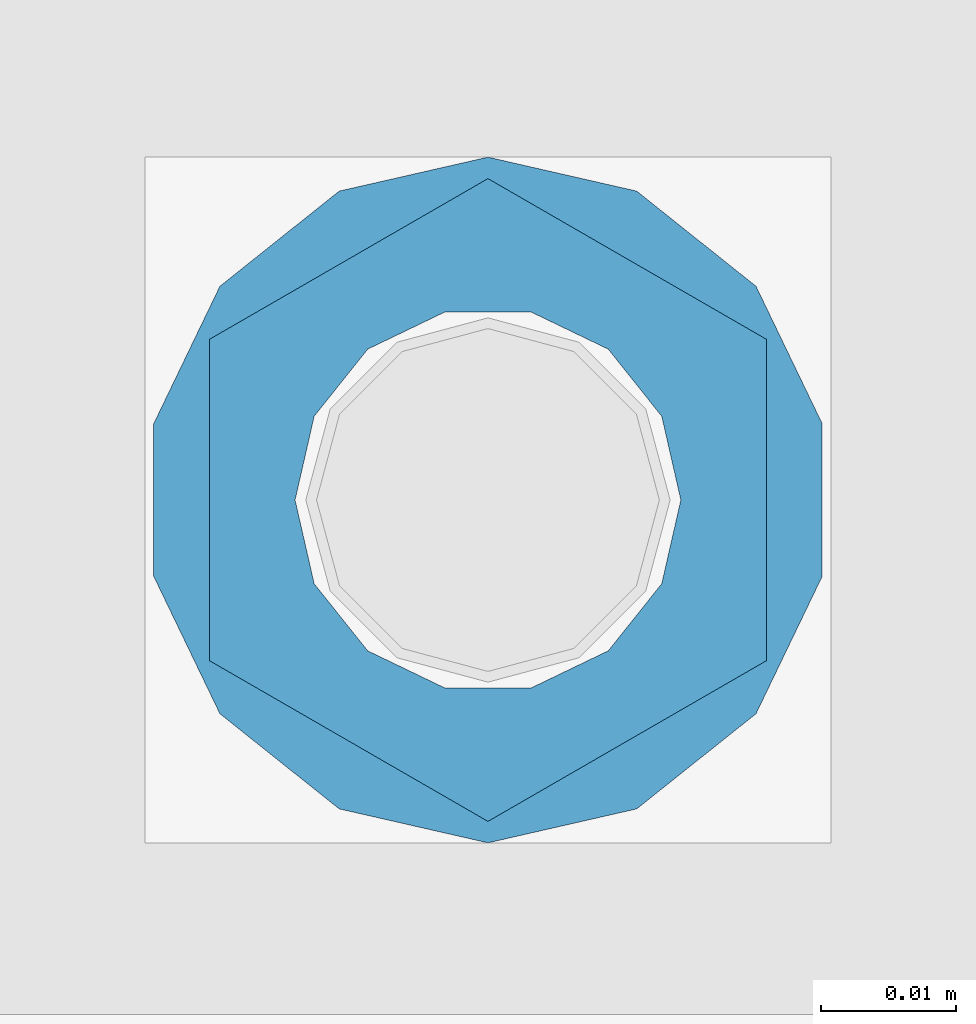
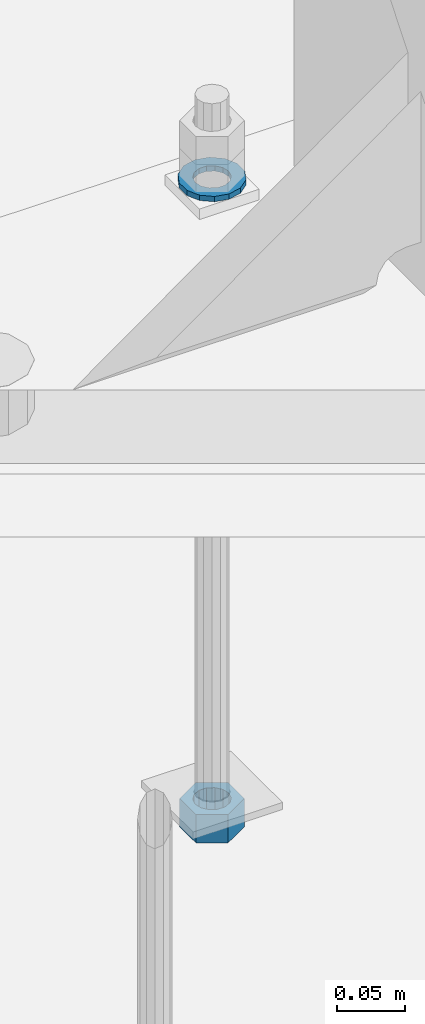
# One storey, part 1027 of 1763: 2 columns, 1 element without a shape of its own.
"""IFC2X3 building model written with IfcOpenShell, lengths in millimetres."""

from ifc_helpers import new_model, si_unit, frame, origin_with_axes, place, context, subcontext, project, spatial, faceted_brep, material, type_object, element, aggregate, save


model = new_model("IFC2X3")

# Units and contexts
model_context = context("Model", 3, precision=1e-05, world=origin_with_axes())
body_context = subcontext(model_context, "Body", "Model", "MODEL_VIEW")
ifc_project = project(units=[si_unit("LENGTHUNIT", "METRE", prefix="MILLI"), si_unit("AREAUNIT", "SQUARE_METRE"), si_unit("VOLUMEUNIT", "CUBIC_METRE"), si_unit("MASSUNIT", "GRAM", prefix="KILO"), si_unit("TIMEUNIT", "SECOND"), si_unit("PLANEANGLEUNIT", "RADIAN"), si_unit("SOLIDANGLEUNIT", "STERADIAN"), si_unit("THERMODYNAMICTEMPERATUREUNIT", "DEGREE_CELSIUS"), si_unit("LUMINOUSINTENSITYUNIT", "LUMEN")], contexts=[model_context])

# Site, building, storey
site_placement = place(None, origin_with_axes())
site = spatial("IfcSite", under=ifc_project, at=site_placement, CompositionType="ELEMENT")
building_placement = place(site_placement, origin_with_axes())
building = spatial("IfcBuilding", under=site, at=building_placement, Name="Undefined", CompositionType="ELEMENT")
storey_placement = place(building_placement, origin_with_axes())
storey = spatial("IfcBuildingStorey", under=building, at=storey_placement, Name="Undefined", CompositionType="ELEMENT", Elevation=0.0)

# Assembly, columns
assembly_placement = place(storey_placement, origin_with_axes())
assembly = element("IfcElementAssembly", 1, at=assembly_placement, inside=storey, Name="TEMPLATE", AssemblyPlace="NOTDEFINED", PredefinedType="RIGID_FRAME")
ifc_material_1 = material(Name="STEEL/A563")
column_type_1 = type_object("IfcColumnType", Name="1_HEAVY_HEX_NUT", PredefinedType="NOTDEFINED")
column_1_placement = place(assembly_placement, frame((-49148.4372736984, 52298.6, -761.999999999999), z_axis=(-1.0, 0.0, 0.0), x_axis=(0.0, 0.0, -1.0)))
column_1 = element("IfcColumn", 2, at=column_1_placement, type_object=column_type_1, material=ifc_material_1, Name="NUT", ObjectType="1_HEAVY_HEX_NUT", context=body_context, shape_type="Brep", body=[
    faceted_brep([(0.0, -23.8099994659424, 0.0), (0.0, -11.9099998474121, -20.6200008392334), (25.4, -11.9099998474121, -20.6200008392334), (25.4, -23.8099994659424, 0.0), (0.0, 11.9099998474121, -20.6200008392334), (25.4, 11.9099998474121, -20.6200008392334), (0.0, 23.8099994659424, 0.0), (25.4, 23.8099994659424, 0.0), (0.0, 11.9099998474121, 20.6200008392334), (25.4, 11.9099998474121, 20.6200008392334), (0.0, -11.9099998474121, 20.6200008392334), (25.4, -11.9099998474121, 20.6200008392334), (0.0, 0.0, 14.289999961853), (0.0, 6.20019861543551, 12.8748450879575), (25.4, 6.20019861543551, 12.8748450879502), (25.4, 0.0, 14.289999961853), (0.0, 11.1723718546418, 8.90966924477834), (25.4, 11.1723718546418, 8.90966924477834), (0.0, 13.9317198278877, 3.17982413774735), (25.4, 13.9317198278877, 3.17982413774007), (0.0, 13.9317198278877, -3.17982413774735), (25.4, 13.9317198278877, -3.17982413774007), (0.0, 11.1723718546418, -8.90966924477834), (25.4, 11.1723718546418, -8.90966924477834), (0.0, 6.20019861543551, -12.8748450879575), (25.4, 6.20019861543551, -12.8748450879502), (0.0, 0.0, -14.289999961853), (25.4, 0.0, -14.289999961853), (0.0, -6.20019861543551, -12.8748450879575), (25.4, -6.20019861543551, -12.8748450879502), (0.0, -11.1723718546418, -8.90966924477834), (25.4, -11.1723718546418, -8.90966924477834), (0.0, -13.9317198278877, -3.17982413774735), (25.4, -13.9317198278877, -3.17982413774007), (0.0, -13.9317198278877, 3.17982413774735), (25.4, -13.9317198278877, 3.17982413774007), (0.0, -11.1723718546418, 8.90966924477834), (25.4, -11.1723718546418, 8.90966924477834), (0.0, -6.20019861543551, 12.8748450879575), (25.4, -6.20019861543551, 12.8748450879502)], [[[0, 1, 2, 3]], [[1, 4, 5, 2]], [[4, 6, 7, 5]], [[6, 8, 9, 7]], [[8, 10, 11, 9]], [[10, 0, 3, 11]], [[12, 13, 14, 15]], [[13, 16, 17, 14]], [[16, 18, 19, 17]], [[18, 20, 21, 19]], [[20, 22, 23, 21]], [[22, 24, 25, 23]], [[24, 26, 27, 25]], [[26, 28, 29, 27]], [[28, 30, 31, 29]], [[30, 32, 33, 31]], [[32, 34, 35, 33]], [[34, 36, 37, 35]], [[36, 38, 39, 37]], [[38, 12, 15, 39]], [[5, 7, 9, 11, 3, 2], [17, 19, 21, 23, 25, 27, 29, 31, 33, 35, 37, 39, 15, 14]], [[10, 8, 6, 4, 1, 0], [38, 36, 34, 32, 30, 28, 26, 24, 22, 20, 18, 16, 13, 12]]]),
])
ifc_material_2 = material(Name="STEEL/F436")
column_type_2 = type_object("IfcColumnType", Name="1_WASHER", PredefinedType="NOTDEFINED")
column_2_placement = place(assembly_placement, frame((-49148.4372736984, 52298.6, -201.612499999999), z_axis=(-1.0, 0.0, 0.0), x_axis=(0.0, 0.0, -1.0)))
column_2 = element("IfcColumn", 3, at=column_2_placement, type_object=column_type_2, material=ifc_material_2, Name="WASHER", ObjectType="1_WASHER", context=body_context, shape_type="Brep", body=[
    faceted_brep([(0.0, -25.4000000000015, 0.0), (0.0, -22.8846089010258, -11.0206468080723), (4.76249999999982, -22.8846089010258, -11.0206468080723), (4.76249999999982, -25.3999996185303, 0.0), (0.0, -15.8366407293724, -19.8585193564359), (4.76249999999982, -15.8366407293724, -19.8585193564359), (0.0, -5.65203163760452, -24.7631685975066), (4.76249999999982, -5.65203163760452, -24.7631685975066), (0.0, 5.65203163760452, -24.7631685975066), (4.76249999999982, 5.65203163760452, -24.7631685975066), (0.0, 15.8366407293724, -19.8585193564359), (4.76249999999982, 15.8366407293724, -19.8585193564359), (0.0, 22.8846089010258, -11.0206468080723), (4.76249999999982, 22.8846089010258, -11.0206468080723), (0.0, 25.4000000000015, 0.0), (4.76249999999982, 25.3999996185303, 0.0), (0.0, 22.8846089010258, 11.0206468080723), (4.76249999999982, 22.8846089010258, 11.0206468080723), (0.0, 15.8366407293724, 19.8585193564359), (4.76249999999982, 15.8366407293724, 19.8585193564359), (0.0, 5.65203163760452, 24.7631685975066), (4.76249999999982, 5.65203163760452, 24.7631685975066), (0.0, -5.65203163760452, 24.7631685975066), (4.76249999999982, -5.65203163760452, 24.7631685975066), (0.0, -15.8366407293724, 19.8585193564359), (4.76249999999982, -15.8366407293724, 19.8585193564359), (0.0, -22.8846089010258, 11.0206468080723), (4.76249999999982, -22.8846089010258, 11.0206468080723), (0.0, 0.0, 14.289999961853), (0.0, 6.20019861543551, 12.8748450879575), (4.76249999999982, 6.20019861543551, 12.8748450879502), (4.76249999999982, 0.0, 14.289999961853), (0.0, 11.1723718546418, 8.90966924477834), (4.76249999999982, 11.1723718546418, 8.90966924477834), (0.0, 13.9317198278877, 3.17982413774735), (4.76249999999982, 13.9317198278877, 3.17982413774007), (0.0, 13.9317198278877, -3.17982413774735), (4.76249999999982, 13.9317198278877, -3.17982413774007), (0.0, 11.1723718546418, -8.90966924477834), (4.76249999999982, 11.1723718546418, -8.90966924477834), (0.0, 6.20019861543551, -12.8748450879575), (4.76249999999982, 6.20019861543551, -12.8748450879502), (0.0, 0.0, -14.289999961853), (4.76249999999982, 0.0, -14.289999961853), (0.0, -6.20019861543551, -12.8748450879575), (4.76249999999982, -6.20019861543551, -12.8748450879502), (0.0, -11.1723718546418, -8.90966924477834), (4.76249999999982, -11.1723718546418, -8.90966924477834), (0.0, -13.9317198278877, -3.17982413774735), (4.76249999999982, -13.9317198278877, -3.17982413774007), (0.0, -13.9317198278877, 3.17982413774735), (4.76249999999982, -13.9317198278877, 3.17982413774007), (0.0, -11.1723718546418, 8.90966924477834), (4.76249999999982, -11.1723718546418, 8.90966924477834), (0.0, -6.20019861543551, 12.8748450879575), (4.76249999999982, -6.20019861543551, 12.8748450879502)], [[[0, 1, 2, 3]], [[1, 4, 5, 2]], [[4, 6, 7, 5]], [[6, 8, 9, 7]], [[8, 10, 11, 9]], [[10, 12, 13, 11]], [[12, 14, 15, 13]], [[14, 16, 17, 15]], [[16, 18, 19, 17]], [[18, 20, 21, 19]], [[20, 22, 23, 21]], [[22, 24, 25, 23]], [[24, 26, 27, 25]], [[26, 0, 3, 27]], [[28, 29, 30, 31]], [[29, 32, 33, 30]], [[32, 34, 35, 33]], [[34, 36, 37, 35]], [[36, 38, 39, 37]], [[38, 40, 41, 39]], [[40, 42, 43, 41]], [[42, 44, 45, 43]], [[44, 46, 47, 45]], [[46, 48, 49, 47]], [[48, 50, 51, 49]], [[50, 52, 53, 51]], [[52, 54, 55, 53]], [[54, 28, 31, 55]], [[5, 7, 9, 11, 13, 15, 17, 19, 21, 23, 25, 27, 3, 2], [33, 35, 37, 39, 41, 43, 45, 47, 49, 51, 53, 55, 31, 30]], [[26, 24, 22, 20, 18, 16, 14, 12, 10, 8, 6, 4, 1, 0], [54, 52, 50, 48, 46, 44, 42, 40, 38, 36, 34, 32, 29, 28]]]),
])
aggregate(assembly, [column_2, column_1])

save(model, "model.ifc")
